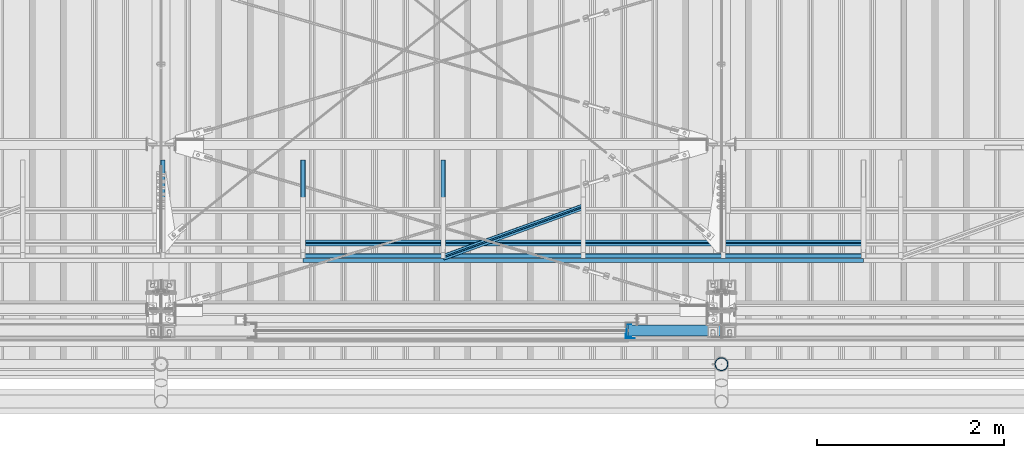
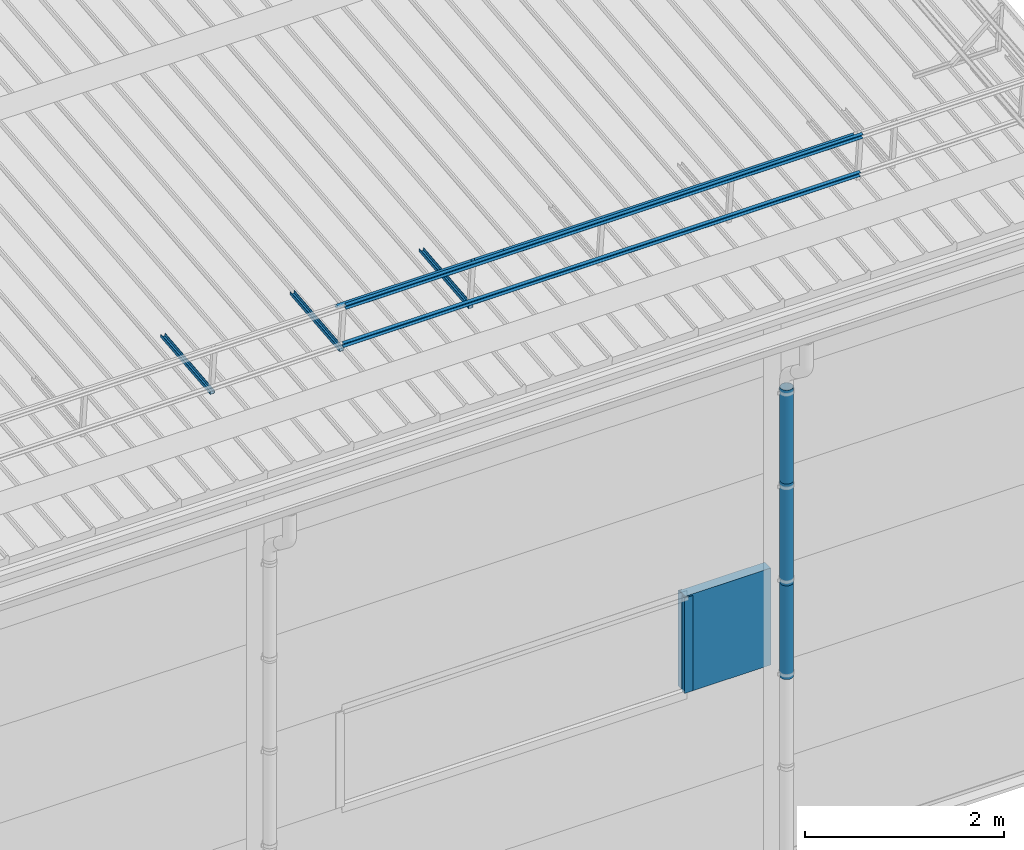
# One storey, part 67 of 709: 13 beams, 13 elements without a shape of their own.
"""IFC4 building model written with IfcOpenShell, lengths in millimetres."""

from ifc_helpers import new_model, si_unit, direction, frame, origin_with_axes, place, context, subcontext, project, spatial, line, indexed_curve, outline, extrude, material, element, aggregate, save


model = new_model("IFC4")

# Units and contexts
model_context = context("Model", 3, precision=0.2, world=origin_with_axes(), true_north=direction((0.0, 1.0)))
body_context = subcontext(model_context, "Body", "Model", "MODEL_VIEW")
ifc_project = project(units=[si_unit("LENGTHUNIT", "METRE", prefix="MILLI"), si_unit("AREAUNIT", "SQUARE_METRE"), si_unit("VOLUMEUNIT", "CUBIC_METRE"), si_unit("MASSUNIT", "GRAM", prefix="KILO"), si_unit("TIMEUNIT", "SECOND"), si_unit("PLANEANGLEUNIT", "RADIAN"), si_unit("SOLIDANGLEUNIT", "STERADIAN"), si_unit("THERMODYNAMICTEMPERATUREUNIT", "DEGREE_CELSIUS"), si_unit("LUMINOUSINTENSITYUNIT", "LUMEN")], contexts=[model_context])

# Site, building, storey
site_placement = place(None, origin_with_axes())
site = spatial("IfcSite", under=ifc_project, at=site_placement, CompositionType="ELEMENT")
building_placement = place(site_placement, origin_with_axes())
building = spatial("IfcBuilding", under=site, at=building_placement, Name="Undefined", CompositionType="ELEMENT")
storey_placement = place(building_placement, origin_with_axes())
storey = spatial("IfcBuildingStorey", under=building, at=storey_placement, Name="Undefined", CompositionType="ELEMENT", Elevation=0.0)

# Assembly, beam
assembly_1_placement = place(storey_placement, frame((40020.0, 768.92298, 7577.16191), z_axis=(0.0, -0.099503719, 0.9950371902), x_axis=(0.0, 0.9950371902, 0.099503719)))
assembly_1 = element("IfcElementAssembly", 1, at=assembly_1_placement, inside=storey)
ifc_material_1 = material(Name="Steel_Undefined", Category="STEEL")
beam_1_placement = place(assembly_1_placement, origin_with_axes())
beam_1 = element("IfcBeam", 2, at=beam_1_placement, material=ifc_material_1, ObjectType="601", context=body_context, shape_type="SolidModel", body=[
    extrude(outline(indexed_curve([(-20.0, -25.0), (20.0, -25.0), (20.0, -22.5), (-17.5, -22.5), (-17.5, 22.5), (20.0, 22.5), (20.0, 25.0), (-20.0, 25.0)], segments=[line(1, 2, 3, 4, 5, 6, 7, 8, 1)])), frame((0.0, 0.0, 0.0), z_axis=(-1.0, 0.0, 0.0), x_axis=(0.0, 0.0, 1.0)), (0.0, 0.0, -1.0), 1000.0),
])
aggregate(assembly_1, [beam_1])

assembly_2_placement = place(storey_placement, frame((41520.0, 768.92298, 7577.16191), z_axis=(0.0, -0.099503719, 0.9950371902), x_axis=(0.0, 0.9950371902, 0.099503719)))
assembly_2 = element("IfcElementAssembly", 3, at=assembly_2_placement, inside=storey)
beam_2_placement = place(assembly_2_placement, origin_with_axes())
beam_2 = element("IfcBeam", 4, at=beam_2_placement, material=ifc_material_1, ObjectType="601", context=body_context, shape_type="SolidModel", body=[
    extrude(outline(indexed_curve([(-20.0, -25.0), (20.0, -25.0), (20.0, -22.5), (-17.5, -22.5), (-17.5, 22.5), (20.0, 22.5), (20.0, 25.0), (-20.0, 25.0)], segments=[line(1, 2, 3, 4, 5, 6, 7, 8, 1)])), frame((0.0, 0.0, 0.0), z_axis=(-1.0, 0.0, 0.0), x_axis=(0.0, 0.0, 1.0)), (0.0, 0.0, -1.0), 1000.0),
])
aggregate(assembly_2, [beam_2])

assembly_3_placement = place(storey_placement, frame((43020.0, 768.92298, 7577.16191), z_axis=(0.0, -0.099503719, 0.9950371902), x_axis=(0.0, 0.9950371902, 0.099503719)))
assembly_3 = element("IfcElementAssembly", 5, at=assembly_3_placement, inside=storey)
beam_3_placement = place(assembly_3_placement, origin_with_axes())
beam_3 = element("IfcBeam", 6, at=beam_3_placement, material=ifc_material_1, ObjectType="601", context=body_context, shape_type="SolidModel", body=[
    extrude(outline(indexed_curve([(-20.0, -25.0), (20.0, -25.0), (20.0, -22.5), (-17.5, -22.5), (-17.5, 22.5), (20.0, 22.5), (20.0, 25.0), (-20.0, 25.0)], segments=[line(1, 2, 3, 4, 5, 6, 7, 8, 1)])), frame((0.0, 0.0, 0.0), z_axis=(-1.0, 0.0, 0.0), x_axis=(0.0, 0.0, 1.0)), (0.0, 0.0, -1.0), 1000.0),
])
aggregate(assembly_3, [beam_3])

assembly_4_placement = place(storey_placement, frame((41520.0, 691.31008, 8152.29341), z_axis=(0.0, -0.9950371902, -0.099503719), x_axis=(1.0, 0.0, 0.0)))
assembly_4 = element("IfcElementAssembly", 7, at=assembly_4_placement, inside=storey)
beam_4_placement = place(assembly_4_placement, origin_with_axes())
beam_4 = element("IfcBeam", 8, at=beam_4_placement, material=ifc_material_1, ObjectType="606", context=body_context, shape_type="SolidModel", body=[
    extrude(outline(indexed_curve([(-20.0, -25.0), (20.0, -25.0), (20.0, -22.5), (-17.5, -22.5), (-17.5, 22.5), (20.0, 22.5), (20.0, 25.0), (-20.0, 25.0)], segments=[line(1, 2, 3, 4, 5, 6, 7, 8, 1)])), frame((0.0, 0.0, 0.0), z_axis=(-1.0, 0.0, 0.0), x_axis=(0.0, 0.0, 1.0)), (0.0, 0.0, -1.0), 6000.0),
])
aggregate(assembly_4, [beam_4])

assembly_5_placement = place(storey_placement, frame((41520.0, 741.06194, 7654.77481), z_axis=(0.0, -0.9950371902, -0.099503719), x_axis=(1.0, 0.0, 0.0)))
assembly_5 = element("IfcElementAssembly", 9, at=assembly_5_placement, inside=storey)
beam_5_placement = place(assembly_5_placement, origin_with_axes())
beam_5 = element("IfcBeam", 10, at=beam_5_placement, material=ifc_material_1, ObjectType="606", context=body_context, shape_type="SolidModel", body=[
    extrude(outline(indexed_curve([(-20.0, -25.0), (20.0, -25.0), (20.0, -22.5), (-17.5, -22.5), (-17.5, 22.5), (20.0, 22.5), (20.0, 25.0), (-20.0, 25.0)], segments=[line(1, 2, 3, 4, 5, 6, 7, 8, 1)])), frame((0.0, 0.0, 0.0), z_axis=(-1.0, 0.0, 0.0), x_axis=(0.0, 0.0, 1.0)), (0.0, 0.0, -1.0), 6000.0),
])
aggregate(assembly_5, [beam_5])

assembly_6_placement = place(storey_placement, frame((41520.0, 878.66704, 8043.11507), z_axis=(0.0, 0.6332377902, 0.7739572992), x_axis=(1.0, 0.0, 0.0)))
assembly_6 = element("IfcElementAssembly", 11, at=assembly_6_placement, inside=storey)
beam_6_placement = place(assembly_6_placement, origin_with_axes())
beam_6 = element("IfcBeam", 12, at=beam_6_placement, material=ifc_material_1, ObjectType="606", context=body_context, shape_type="SolidModel", body=[
    extrude(outline(indexed_curve([(-20.0, -25.0), (20.0, -25.0), (20.0, -22.5), (-17.5, -22.5), (-17.5, 22.5), (20.0, 22.5), (20.0, 25.0), (-20.0, 25.0)], segments=[line(1, 2, 3, 4, 5, 6, 7, 8, 1)])), frame((0.0, 0.0, 0.0), z_axis=(-1.0, 0.0, 0.0), x_axis=(0.0, 0.0, 1.0)), (0.0, 0.0, -1.0), 6000.0),
])
aggregate(assembly_6, [beam_6])

assembly_7_placement = place(storey_placement, frame((43020.0, 723.87558, 8169.76263), z_axis=(0.0, 0.6332377902, 0.7739572992), x_axis=(0.9061831398, 0.3272952929, -0.2677870579)))
assembly_7 = element("IfcElementAssembly", 13, at=assembly_7_placement, inside=storey)
beam_7_placement = place(assembly_7_placement, origin_with_axes())
beam_7 = element("IfcBeam", 14, at=beam_7_placement, material=ifc_material_1, ObjectType="605", context=body_context, shape_type="SolidModel", body=[
    extrude(outline(indexed_curve([(-20.0, -25.0), (20.0, -25.0), (20.0, -22.5), (-17.5, -22.5), (-17.5, 22.5), (20.0, 22.5), (20.0, 25.0), (-20.0, 25.0)], segments=[line(1, 2, 3, 4, 5, 6, 7, 8, 1)])), frame((0.0, 0.0, 0.0), z_axis=(-1.0, 0.0, 0.0), x_axis=(0.0, 0.0, 1.0)), (0.0, 0.0, -1.0), 1655.29454),
])
aggregate(assembly_7, [beam_7])

assembly_8_placement = place(storey_placement, frame((45000.0, -60.0, 3275.0), z_axis=(0.0, 0.0, -1.0), x_axis=(1.0, 0.0, 0.0)))
assembly_8 = element("IfcElementAssembly", 15, at=assembly_8_placement, inside=storey)
ifc_material_2 = material(Name="Insulation", Category="Insulation")
beam_8_placement = place(assembly_8_placement, origin_with_axes())
beam_8 = element("IfcBeam", 16, at=beam_8_placement, material=ifc_material_2, ObjectType="P-110", context=body_context, shape_type="SolidModel", body=[
    extrude(outline(indexed_curve([(-595.0, -60.0), (595.0, -60.0), (595.0, 60.0), (-595.0, 60.0)], segments=[line(1, 2, 3, 4, 1)])), frame((0.0, 0.0, 0.0), z_axis=(-1.0, 0.0, 0.0), x_axis=(0.0, 0.0, 1.0)), (0.0, 0.0, -1.0), 990.0),
])
aggregate(assembly_8, [beam_8])

assembly_9_placement = place(storey_placement, frame((45010.0, -60.0, 3870.0), z_axis=(0.0, 1.0, 0.0), x_axis=(0.0, 0.0, -1.0)))
assembly_9 = element("IfcElementAssembly", 17, at=assembly_9_placement, inside=storey)
beam_9_placement = place(assembly_9_placement, origin_with_axes())
beam_9 = element("IfcBeam", 18, at=beam_9_placement, material=ifc_material_1, context=body_context, shape_type="SolidModel", body=[
    extrude(outline(indexed_curve([(-70.0, -25.0), (-68.0, -25.0), (-68.0, 23.0), (68.0, 23.0), (68.0, -25.0), (70.0, -25.0), (70.0, 25.0), (-70.0, 25.0)], segments=[line(1, 2, 3, 4, 5, 6, 7, 8, 1)])), frame((0.0, 0.0, 0.0), z_axis=(-1.0, 0.0, 0.0), x_axis=(0.0, 0.0, 1.0)), (0.0, 0.0, -1.0), 1170.0),
])
aggregate(assembly_9, [beam_9])

assembly_10_placement = place(storey_placement, frame((44975.0, -119.0, 3870.0), z_axis=(0.0, -1.0, 0.0), x_axis=(0.0, 0.0, -1.0)))
assembly_10 = element("IfcElementAssembly", 19, at=assembly_10_placement, inside=storey)
beam_10_placement = place(assembly_10_placement, origin_with_axes())
beam_10 = element("IfcBeam", 20, at=beam_10_placement, material=ifc_material_1, context=body_context, shape_type="SolidModel", body=[
    extrude(outline(indexed_curve([(-25.0, -1.0), (25.0, -1.0), (25.0, 99.0), (23.0, 99.0), (23.0, 1.0), (-25.0, 1.0)], segments=[line(1, 2, 3, 4, 5, 6, 1)])), frame((0.0, 0.0, 0.0), z_axis=(-1.0, 0.0, 0.0), x_axis=(0.0, 0.0, 1.0)), (0.0, 0.0, -1.0), 1170.0),
])
aggregate(assembly_10, [beam_10])

assembly_11_placement = place(storey_placement, frame((46000.0, -420.0, 6276.92297), z_axis=(0.0, 1.0, 0.0), x_axis=(0.0, 0.0, -1.0)))
assembly_11 = element("IfcElementAssembly", 21, at=assembly_11_placement, inside=storey)
beam_11_placement = place(assembly_11_placement, origin_with_axes())
beam_11 = element("IfcBeam", 22, at=beam_11_placement, material=ifc_material_1, ObjectType="614", context=body_context, shape_type="SolidModel", body=[
    extrude(outline(indexed_curve([(70.0, 0.0), (69.61653, 7.31699), (68.47033, 14.55382), (66.57396, 21.63119), (63.94818, 28.47157), (60.62178, 35.0), (56.63119, 41.14497), (52.02014, 46.83914), (46.83914, 52.02014), (41.14497, 56.63119), (35.0, 60.62178), (28.47157, 63.94818), (21.63119, 66.57396), (14.55382, 68.47033), (7.31699, 69.61653), (0.0, 70.0), (-7.31699, 69.61653), (-14.55382, 68.47033), (-21.63119, 66.57396), (-28.47157, 63.94818), (-35.0, 60.62178), (-41.14497, 56.63119), (-46.83914, 52.02014), (-52.02014, 46.83914), (-56.63119, 41.14497), (-60.62178, 35.0), (-63.94818, 28.47157), (-66.57396, 21.63119), (-68.47033, 14.55382), (-69.61653, 7.31699), (-70.0, 0.0), (-69.61653, -7.31699), (-68.47033, -14.55382), (-66.57396, -21.63119), (-63.94818, -28.47157), (-60.62178, -35.0), (-56.63119, -41.14497), (-52.02014, -46.83914), (-46.83914, -52.02014), (-41.14497, -56.63119), (-35.0, -60.62178), (-28.47157, -63.94818), (-21.63119, -66.57396), (-14.55382, -68.47033), (-7.31699, -69.61653), (0.0, -70.0), (7.31699, -69.61653), (14.55382, -68.47033), (21.63119, -66.57396), (28.47157, -63.94818), (35.0, -60.62178), (41.14497, -56.63119), (46.83914, -52.02014), (52.02014, -46.83914), (56.63119, -41.14497), (60.62178, -35.0), (63.94818, -28.47157), (66.57396, -21.63119), (68.47033, -14.55382), (69.61653, -7.31699)], segments=[line(1, 2, 3, 4, 5, 6, 7, 8, 9, 10, 11, 12, 13, 14, 15, 16, 17, 18, 19, 20, 21, 22, 23, 24, 25, 26, 27, 28, 29, 30, 31, 32, 33, 34, 35, 36, 37, 38, 39, 40, 41, 42, 43, 44, 45, 46, 47, 48, 49, 50, 51, 52, 53, 54, 55, 56, 57, 58, 59, 60, 1)]), holes=[indexed_curve([(65.0, 0.0), (64.64392, -6.79435), (63.57959, -13.51426), (61.81867, -20.0861), (59.38045, -26.43788), (56.29165, -32.5), (52.5861, -38.20604), (48.30441, -43.49349), (43.49349, -48.30441), (38.20604, -52.5861), (32.5, -56.29165), (26.43788, -59.38045), (20.0861, -61.81867), (13.51426, -63.57959), (6.79435, -64.64392), (0.0, -65.0), (-6.79435, -64.64392), (-13.51426, -63.57959), (-20.0861, -61.81867), (-26.43788, -59.38045), (-32.5, -56.29165), (-38.20604, -52.5861), (-43.49349, -48.30441), (-48.30441, -43.49349), (-52.5861, -38.20604), (-56.29165, -32.5), (-59.38045, -26.43788), (-61.81867, -20.0861), (-63.57959, -13.51426), (-64.64392, -6.79435), (-65.0, 0.0), (-64.64392, 6.79435), (-63.57959, 13.51426), (-61.81867, 20.0861), (-59.38045, 26.43788), (-56.29165, 32.5), (-52.5861, 38.20604), (-48.30441, 43.49349), (-43.49349, 48.30441), (-38.20604, 52.5861), (-32.5, 56.29165), (-26.43788, 59.38045), (-20.0861, 61.81867), (-13.51426, 63.57959), (-6.79435, 64.64392), (0.0, 65.0), (6.79435, 64.64392), (13.51426, 63.57959), (20.0861, 61.81867), (26.43788, 59.38045), (32.5, 56.29165), (38.20604, 52.5861), (43.49349, 48.30441), (48.30441, 43.49349), (52.5861, 38.20604), (56.29165, 32.5), (59.38045, 26.43788), (61.81867, 20.0861), (63.57959, 13.51426), (64.64392, 6.79435)], segments=[line(1, 2, 3, 4, 5, 6, 7, 8, 9, 10, 11, 12, 13, 14, 15, 16, 17, 18, 19, 20, 21, 22, 23, 24, 25, 26, 27, 28, 29, 30, 31, 32, 33, 34, 35, 36, 37, 38, 39, 40, 41, 42, 43, 44, 45, 46, 47, 48, 49, 50, 51, 52, 53, 54, 55, 56, 57, 58, 59, 60, 1)])]), frame((0.0, 0.0, 0.0), z_axis=(-1.0, 0.0, 0.0), x_axis=(0.0, 0.0, 1.0)), (0.0, 0.0, -1.0), 1250.0),
])
aggregate(assembly_11, [beam_11])

assembly_12_placement = place(storey_placement, frame((46000.0, -420.0, 5126.92297), z_axis=(0.0, 1.0, 0.0), x_axis=(0.0, 0.0, -1.0)))
assembly_12 = element("IfcElementAssembly", 23, at=assembly_12_placement, inside=storey)
beam_12_placement = place(assembly_12_placement, origin_with_axes())
beam_12 = element("IfcBeam", 24, at=beam_12_placement, material=ifc_material_1, ObjectType="614", context=body_context, shape_type="SolidModel", body=[
    extrude(outline(indexed_curve([(70.0, 0.0), (69.61653, 7.31699), (68.47033, 14.55382), (66.57396, 21.63119), (63.94818, 28.47157), (60.62178, 35.0), (56.63119, 41.14497), (52.02014, 46.83914), (46.83914, 52.02014), (41.14497, 56.63119), (35.0, 60.62178), (28.47157, 63.94818), (21.63119, 66.57396), (14.55382, 68.47033), (7.31699, 69.61653), (0.0, 70.0), (-7.31699, 69.61653), (-14.55382, 68.47033), (-21.63119, 66.57396), (-28.47157, 63.94818), (-35.0, 60.62178), (-41.14497, 56.63119), (-46.83914, 52.02014), (-52.02014, 46.83914), (-56.63119, 41.14497), (-60.62178, 35.0), (-63.94818, 28.47157), (-66.57396, 21.63119), (-68.47033, 14.55382), (-69.61653, 7.31699), (-70.0, 0.0), (-69.61653, -7.31699), (-68.47033, -14.55382), (-66.57396, -21.63119), (-63.94818, -28.47157), (-60.62178, -35.0), (-56.63119, -41.14497), (-52.02014, -46.83914), (-46.83914, -52.02014), (-41.14497, -56.63119), (-35.0, -60.62178), (-28.47157, -63.94818), (-21.63119, -66.57396), (-14.55382, -68.47033), (-7.31699, -69.61653), (0.0, -70.0), (7.31699, -69.61653), (14.55382, -68.47033), (21.63119, -66.57396), (28.47157, -63.94818), (35.0, -60.62178), (41.14497, -56.63119), (46.83914, -52.02014), (52.02014, -46.83914), (56.63119, -41.14497), (60.62178, -35.0), (63.94818, -28.47157), (66.57396, -21.63119), (68.47033, -14.55382), (69.61653, -7.31699)], segments=[line(1, 2, 3, 4, 5, 6, 7, 8, 9, 10, 11, 12, 13, 14, 15, 16, 17, 18, 19, 20, 21, 22, 23, 24, 25, 26, 27, 28, 29, 30, 31, 32, 33, 34, 35, 36, 37, 38, 39, 40, 41, 42, 43, 44, 45, 46, 47, 48, 49, 50, 51, 52, 53, 54, 55, 56, 57, 58, 59, 60, 1)]), holes=[indexed_curve([(65.0, 0.0), (64.64392, -6.79435), (63.57959, -13.51426), (61.81867, -20.0861), (59.38045, -26.43788), (56.29165, -32.5), (52.5861, -38.20604), (48.30441, -43.49349), (43.49349, -48.30441), (38.20604, -52.5861), (32.5, -56.29165), (26.43788, -59.38045), (20.0861, -61.81867), (13.51426, -63.57959), (6.79435, -64.64392), (0.0, -65.0), (-6.79435, -64.64392), (-13.51426, -63.57959), (-20.0861, -61.81867), (-26.43788, -59.38045), (-32.5, -56.29165), (-38.20604, -52.5861), (-43.49349, -48.30441), (-48.30441, -43.49349), (-52.5861, -38.20604), (-56.29165, -32.5), (-59.38045, -26.43788), (-61.81867, -20.0861), (-63.57959, -13.51426), (-64.64392, -6.79435), (-65.0, 0.0), (-64.64392, 6.79435), (-63.57959, 13.51426), (-61.81867, 20.0861), (-59.38045, 26.43788), (-56.29165, 32.5), (-52.5861, 38.20604), (-48.30441, 43.49349), (-43.49349, 48.30441), (-38.20604, 52.5861), (-32.5, 56.29165), (-26.43788, 59.38045), (-20.0861, 61.81867), (-13.51426, 63.57959), (-6.79435, 64.64392), (0.0, 65.0), (6.79435, 64.64392), (13.51426, 63.57959), (20.0861, 61.81867), (26.43788, 59.38045), (32.5, 56.29165), (38.20604, 52.5861), (43.49349, 48.30441), (48.30441, 43.49349), (52.5861, 38.20604), (56.29165, 32.5), (59.38045, 26.43788), (61.81867, 20.0861), (63.57959, 13.51426), (64.64392, 6.79435)], segments=[line(1, 2, 3, 4, 5, 6, 7, 8, 9, 10, 11, 12, 13, 14, 15, 16, 17, 18, 19, 20, 21, 22, 23, 24, 25, 26, 27, 28, 29, 30, 31, 32, 33, 34, 35, 36, 37, 38, 39, 40, 41, 42, 43, 44, 45, 46, 47, 48, 49, 50, 51, 52, 53, 54, 55, 56, 57, 58, 59, 60, 1)])]), frame((0.0, 0.0, 0.0), z_axis=(-1.0, 0.0, 0.0), x_axis=(0.0, 0.0, 1.0)), (0.0, 0.0, -1.0), 1250.0),
])
aggregate(assembly_12, [beam_12])

assembly_13_placement = place(storey_placement, frame((46000.0, -420.0, 3976.92297), z_axis=(0.0, 1.0, 0.0), x_axis=(0.0, 0.0, -1.0)))
assembly_13 = element("IfcElementAssembly", 25, at=assembly_13_placement, inside=storey)
beam_13_placement = place(assembly_13_placement, origin_with_axes())
beam_13 = element("IfcBeam", 26, at=beam_13_placement, material=ifc_material_1, ObjectType="614", context=body_context, shape_type="SolidModel", body=[
    extrude(outline(indexed_curve([(70.0, 0.0), (69.61653, 7.31699), (68.47033, 14.55382), (66.57396, 21.63119), (63.94818, 28.47157), (60.62178, 35.0), (56.63119, 41.14497), (52.02014, 46.83914), (46.83914, 52.02014), (41.14497, 56.63119), (35.0, 60.62178), (28.47157, 63.94818), (21.63119, 66.57396), (14.55382, 68.47033), (7.31699, 69.61653), (0.0, 70.0), (-7.31699, 69.61653), (-14.55382, 68.47033), (-21.63119, 66.57396), (-28.47157, 63.94818), (-35.0, 60.62178), (-41.14497, 56.63119), (-46.83914, 52.02014), (-52.02014, 46.83914), (-56.63119, 41.14497), (-60.62178, 35.0), (-63.94818, 28.47157), (-66.57396, 21.63119), (-68.47033, 14.55382), (-69.61653, 7.31699), (-70.0, 0.0), (-69.61653, -7.31699), (-68.47033, -14.55382), (-66.57396, -21.63119), (-63.94818, -28.47157), (-60.62178, -35.0), (-56.63119, -41.14497), (-52.02014, -46.83914), (-46.83914, -52.02014), (-41.14497, -56.63119), (-35.0, -60.62178), (-28.47157, -63.94818), (-21.63119, -66.57396), (-14.55382, -68.47033), (-7.31699, -69.61653), (0.0, -70.0), (7.31699, -69.61653), (14.55382, -68.47033), (21.63119, -66.57396), (28.47157, -63.94818), (35.0, -60.62178), (41.14497, -56.63119), (46.83914, -52.02014), (52.02014, -46.83914), (56.63119, -41.14497), (60.62178, -35.0), (63.94818, -28.47157), (66.57396, -21.63119), (68.47033, -14.55382), (69.61653, -7.31699)], segments=[line(1, 2, 3, 4, 5, 6, 7, 8, 9, 10, 11, 12, 13, 14, 15, 16, 17, 18, 19, 20, 21, 22, 23, 24, 25, 26, 27, 28, 29, 30, 31, 32, 33, 34, 35, 36, 37, 38, 39, 40, 41, 42, 43, 44, 45, 46, 47, 48, 49, 50, 51, 52, 53, 54, 55, 56, 57, 58, 59, 60, 1)]), holes=[indexed_curve([(65.0, 0.0), (64.64392, -6.79435), (63.57959, -13.51426), (61.81867, -20.0861), (59.38045, -26.43788), (56.29165, -32.5), (52.5861, -38.20604), (48.30441, -43.49349), (43.49349, -48.30441), (38.20604, -52.5861), (32.5, -56.29165), (26.43788, -59.38045), (20.0861, -61.81867), (13.51426, -63.57959), (6.79435, -64.64392), (0.0, -65.0), (-6.79435, -64.64392), (-13.51426, -63.57959), (-20.0861, -61.81867), (-26.43788, -59.38045), (-32.5, -56.29165), (-38.20604, -52.5861), (-43.49349, -48.30441), (-48.30441, -43.49349), (-52.5861, -38.20604), (-56.29165, -32.5), (-59.38045, -26.43788), (-61.81867, -20.0861), (-63.57959, -13.51426), (-64.64392, -6.79435), (-65.0, 0.0), (-64.64392, 6.79435), (-63.57959, 13.51426), (-61.81867, 20.0861), (-59.38045, 26.43788), (-56.29165, 32.5), (-52.5861, 38.20604), (-48.30441, 43.49349), (-43.49349, 48.30441), (-38.20604, 52.5861), (-32.5, 56.29165), (-26.43788, 59.38045), (-20.0861, 61.81867), (-13.51426, 63.57959), (-6.79435, 64.64392), (0.0, 65.0), (6.79435, 64.64392), (13.51426, 63.57959), (20.0861, 61.81867), (26.43788, 59.38045), (32.5, 56.29165), (38.20604, 52.5861), (43.49349, 48.30441), (48.30441, 43.49349), (52.5861, 38.20604), (56.29165, 32.5), (59.38045, 26.43788), (61.81867, 20.0861), (63.57959, 13.51426), (64.64392, 6.79435)], segments=[line(1, 2, 3, 4, 5, 6, 7, 8, 9, 10, 11, 12, 13, 14, 15, 16, 17, 18, 19, 20, 21, 22, 23, 24, 25, 26, 27, 28, 29, 30, 31, 32, 33, 34, 35, 36, 37, 38, 39, 40, 41, 42, 43, 44, 45, 46, 47, 48, 49, 50, 51, 52, 53, 54, 55, 56, 57, 58, 59, 60, 1)])]), frame((0.0, 0.0, 0.0), z_axis=(-1.0, 0.0, 0.0), x_axis=(0.0, 0.0, 1.0)), (0.0, 0.0, -1.0), 1250.0),
])
aggregate(assembly_13, [beam_13])

save(model, "model.ifc")
